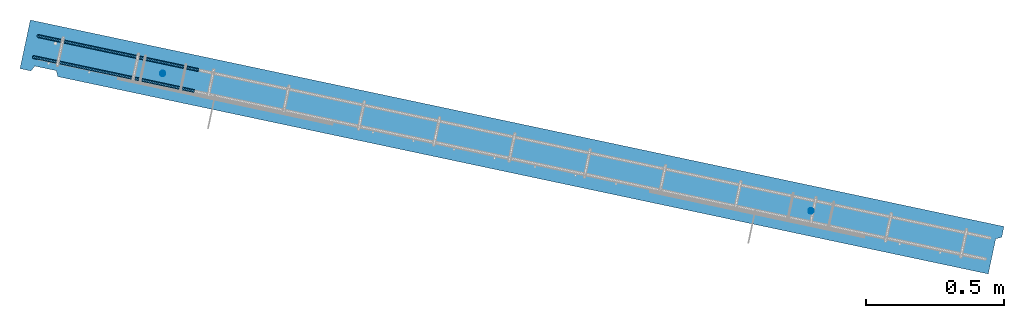
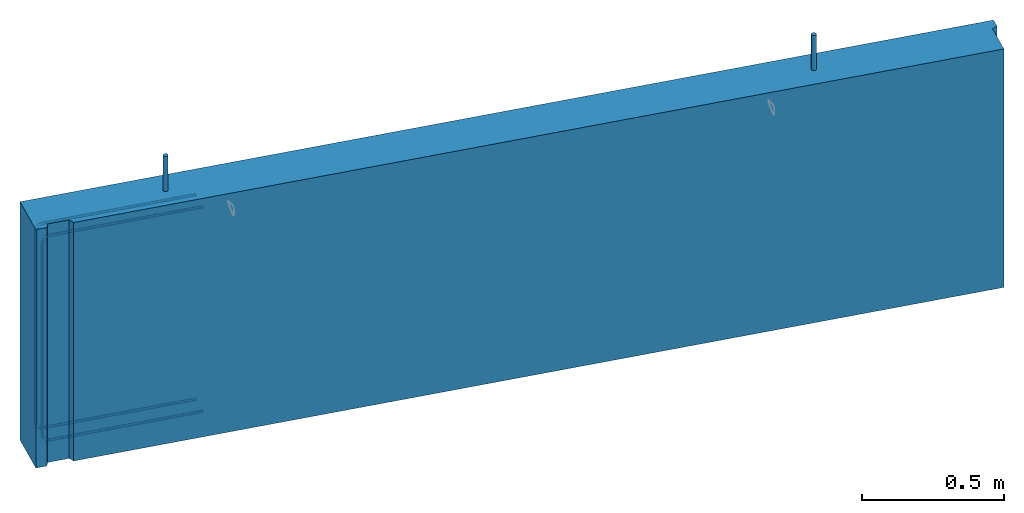
# One storey, part 1 of 5: 2 reinforcing bars, 1 wall, 1 element without a shape of its own.
"""IFC2X3 building model written with IfcOpenShell, lengths in millimetres."""

from ifc_helpers import new_model, entity, si_unit, frame, frame_2d, origin_with_axes, place, context, subcontext, project, spatial, polyline, rectangle, outline, extrude, boolean, source, transform, mapped, material, type_object, element, aggregate, save


model = new_model("IFC2X3")

# Units and contexts
model_context = context("Model", 3, precision=1e-05, world=origin_with_axes())
body_context = subcontext(model_context, "Body", "Model", "MODEL_VIEW")
ifc_project = project(units=[si_unit("LENGTHUNIT", "METRE", prefix="MILLI"), si_unit("AREAUNIT", "SQUARE_METRE"), si_unit("VOLUMEUNIT", "CUBIC_METRE"), si_unit("MASSUNIT", "GRAM", prefix="KILO"), si_unit("TIMEUNIT", "SECOND"), si_unit("PLANEANGLEUNIT", "RADIAN"), si_unit("SOLIDANGLEUNIT", "STERADIAN"), si_unit("THERMODYNAMICTEMPERATUREUNIT", "DEGREE_CELSIUS"), si_unit("LUMINOUSINTENSITYUNIT", "LUMEN")], contexts=[model_context])

# Site, building, storey
site_placement = place(None, origin_with_axes())
site = spatial("IfcSite", under=ifc_project, at=site_placement, CompositionType="ELEMENT")
building_placement = place(site_placement, origin_with_axes())
building = spatial("IfcBuilding", under=site, at=building_placement, Name="1", CompositionType="ELEMENT")
storey_placement = place(building_placement, origin_with_axes())
storey = spatial("IfcBuildingStorey", under=building, at=storey_placement, CompositionType="ELEMENT", Elevation=0.0)

# Assembly, wall, reinforcing bars
assembly_placement = place(storey_placement, origin_with_axes())
assembly = element("IfcElementAssembly", 1, at=assembly_placement, inside=storey, AssemblyPlace="NOTDEFINED", PredefinedType="REINFORCEMENT_UNIT")
ifc_material_1 = material(Name="CONCRETE/C30/37")
wall_type = type_object("IfcWallType", Name="1025X180", PredefinedType="NOTDEFINED")
wall_placement = place(assembly_placement, frame((284.52490144501, 6004.50575262965, 0.0), z_axis=(0.0, 0.0, 1.0), x_axis=(0.978240300403819, -0.207475094085641, 0.0)))
wall = element("IfcWall", 2, at=wall_placement, type_object=wall_type, material=ifc_material_1, ObjectType="1025X180", context=body_context, shape_type="CSG", body=[
    boolean("DIFFERENCE", boolean("DIFFERENCE", extrude(rectangle(XDim=3604.29647202172, YDim=180.0, at=frame_2d((0.0, 1802.14823601086), x_axis=(0.0, -1.0))), frame((0.0, 0.0, 0.0), z_axis=(0.0, 0.0, 1.0), x_axis=(0.0, -1.0, 0.0)), (0.0, 0.0, 1.0), 1025.0), extrude(outline(polyline([(0.0, 0.0), (139.999999999925, -5.13864506501704e-11), (129.999999999931, 19.9999999999877), (-9.09494701772928e-13, 19.9999999999891), (0.0, 0.0)])), frame((3604.29647202145, -89.9999999997517, -1.13686837721616e-13), z_axis=(0.0, 0.0, 1.0), x_axis=(0.0, 1.0, 0.0)), (0.0, 0.0, 1.0), 1025.0)), extrude(outline(polyline([(0.0, 0.0), (99.4114990234532, 2.09183781407773e-11), (89.4114990234559, 20.0000000000036), (10.0000000000226, 19.9999999999891), (0.0, 0.0)])), frame((40.5933694972099, -89.9999999999927, -9.09494701772928e-13), z_axis=(0.0, 0.0, 1.0), x_axis=(1.0, 0.0, 0.0)), (0.0, 0.0, 1.0), 1025.0)),
])
ifc_material_2 = material(Name="B500B")
shared_shape_1 = source(origin_with_axes(), body_context, "Body", "AdvancedSweptSolid", [
    entity("IfcSweptDiskSolid", entity("IfcTrimmedCurve", entity("IfcLine", entity("IfcCartesianPoint", [0.0, 0.0, 0.0]), entity("IfcVector", entity("IfcDirection", [0.999999999180548, -3.81768204722847e-05, -1.34697490605237e-05]), 1.0)), [entity("IfcParameterValue", 0.0)], [entity("IfcParameterValue", 799.999995410812)], True, "PARAMETER"), 9.5, None, 0.0, 799.999995410812),
])
shared_shape_2 = source(origin_with_axes(), body_context, "Body", "AdvancedSweptSolid", [
    entity("IfcSweptDiskSolid", entity("IfcTrimmedCurve", entity("IfcLine", entity("IfcCartesianPoint", [0.0, 0.0, 0.0]), entity("IfcVector", entity("IfcDirection", [0.999999999180548, -3.81768204722847e-05, -1.34697490605237e-05]), 1.0)), [entity("IfcParameterValue", 0.0)], [entity("IfcParameterValue", 799.999995410812)], True, "PARAMETER"), 9.5, None, 0.0, 799.999995410812),
])
reinforcing_bar_1_placement = place(assembly_placement, frame((1953.46447190107, 5650.29907170582, 575.000000009401), z_axis=(-0.895656494371848, 0.444746494184645, 0.0), x_axis=(0.0, 0.0, 1.0)))
reinforcing_bar_1 = element("IfcReinforcingBar", 3, at=reinforcing_bar_1_placement, material=ifc_material_2, BarRole="NOTDEFINED", CrossSectionArea=0.0, NominalDiameter=19.0, context=body_context, shape_type="MappedRepresentation", body=[
    mapped(shared_shape_1, transform((-199.999994751047, -297.985466949513, 1158.91732586056))),
    mapped(shared_shape_2, transform((-199.999994751794, 300.186784957253, -1165.34383783222))),
])
ifc_direction_1 = entity("IfcDirection", [0.0, 0.0, -1.0])
ifc_direction_2 = entity("IfcDirection", [0.0, -1.0, 0.0])
shared_shape_3 = source(origin_with_axes(), body_context, "Body", "AdvancedSweptSolid", [
    entity("IfcSweptDiskSolid", entity("IfcCompositeCurve", [entity("IfcCompositeCurveSegment", "CONTINUOUS", True, entity("IfcTrimmedCurve", entity("IfcLine", entity("IfcCartesianPoint", [0.0, 0.0, 0.0]), entity("IfcVector", ifc_direction_1, 1.0)), [entity("IfcParameterValue", 0.0)], [entity("IfcParameterValue", 564.999999999951)], True, "PARAMETER")), entity("IfcCompositeCurveSegment", "CONTINUOUS", True, entity("IfcTrimmedCurve", entity("IfcCircle", entity("IfcAxis2Placement3D", entity("IfcCartesianPoint", [29.0, -2.33576713526418e-10, -564.999999999951]), ifc_direction_2, entity("IfcDirection", [-1.0, 0.0, -6.18717668181185e-14])), 29.0), [entity("IfcParameterValue", 0.0)], [entity("IfcParameterValue", 1.5707963267949)], True, "PARAMETER")), entity("IfcCompositeCurveSegment", "CONTINUOUS", True, entity("IfcTrimmedCurve", entity("IfcLine", entity("IfcCartesianPoint", [29.0, -2.45563569478691e-10, -593.999999999951]), entity("IfcVector", entity("IfcDirection", [1.0, 0.0, 0.0]), 1.0)), [entity("IfcParameterValue", 0.0)], [entity("IfcParameterValue", 821.0)], True, "PARAMETER")), entity("IfcCompositeCurveSegment", "CONTINUOUS", True, entity("IfcTrimmedCurve", entity("IfcCircle", entity("IfcAxis2Placement3D", entity("IfcCartesianPoint", [850.0, -2.33576713526418e-10, -564.999999999951]), ifc_direction_2, ifc_direction_1), 29.0), [entity("IfcParameterValue", 0.0)], [entity("IfcParameterValue", 1.5707963267949)], True, "PARAMETER")), entity("IfcCompositeCurveSegment", "DISCONTINUOUS", True, entity("IfcTrimmedCurve", entity("IfcLine", entity("IfcCartesianPoint", [879.0, -2.33576713526418e-10, -564.999999999951]), entity("IfcVector", entity("IfcDirection", [0.0, 0.0, 1.0]), 1.0)), [entity("IfcParameterValue", 0.0)], [entity("IfcParameterValue", 564.999999999951)], True, "PARAMETER"))], False), 6.0, None, 0.0, 1954.14159265349),
])
ifc_direction_3 = entity("IfcDirection", [0.0, 0.0, -1.0])
ifc_direction_4 = entity("IfcDirection", [0.0, -1.0, 0.0])
shared_shape_4 = source(origin_with_axes(), body_context, "Body", "AdvancedSweptSolid", [
    entity("IfcSweptDiskSolid", entity("IfcCompositeCurve", [entity("IfcCompositeCurveSegment", "CONTINUOUS", True, entity("IfcTrimmedCurve", entity("IfcLine", entity("IfcCartesianPoint", [0.0, 0.0, 0.0]), entity("IfcVector", ifc_direction_3, 1.0)), [entity("IfcParameterValue", 0.0)], [entity("IfcParameterValue", 564.999999999951)], True, "PARAMETER")), entity("IfcCompositeCurveSegment", "CONTINUOUS", True, entity("IfcTrimmedCurve", entity("IfcCircle", entity("IfcAxis2Placement3D", entity("IfcCartesianPoint", [29.0, -2.33576713526418e-10, -564.999999999951]), ifc_direction_4, entity("IfcDirection", [-1.0, 0.0, -6.18717668181185e-14])), 29.0), [entity("IfcParameterValue", 0.0)], [entity("IfcParameterValue", 1.5707963267949)], True, "PARAMETER")), entity("IfcCompositeCurveSegment", "CONTINUOUS", True, entity("IfcTrimmedCurve", entity("IfcLine", entity("IfcCartesianPoint", [29.0, -2.45563569478691e-10, -593.999999999951]), entity("IfcVector", entity("IfcDirection", [1.0, 0.0, 0.0]), 1.0)), [entity("IfcParameterValue", 0.0)], [entity("IfcParameterValue", 821.0)], True, "PARAMETER")), entity("IfcCompositeCurveSegment", "CONTINUOUS", True, entity("IfcTrimmedCurve", entity("IfcCircle", entity("IfcAxis2Placement3D", entity("IfcCartesianPoint", [850.0, -2.33576713526418e-10, -564.999999999951]), ifc_direction_4, ifc_direction_3), 29.0), [entity("IfcParameterValue", 0.0)], [entity("IfcParameterValue", 1.5707963267949)], True, "PARAMETER")), entity("IfcCompositeCurveSegment", "DISCONTINUOUS", True, entity("IfcTrimmedCurve", entity("IfcLine", entity("IfcCartesianPoint", [879.0, -2.33576713526418e-10, -564.999999999951]), entity("IfcVector", entity("IfcDirection", [0.0, 0.0, 1.0]), 1.0)), [entity("IfcParameterValue", 0.0)], [entity("IfcParameterValue", 564.999999999951)], True, "PARAMETER"))], False), 6.0, None, 0.0, 1954.14159265349),
])
reinforcing_bar_2_placement = place(assembly_placement, frame((265.852100000352, 5916.46370000477, 1025.0), z_axis=(0.978240300403819, -0.207475094085641, 0.0), x_axis=(0.0, 0.0, -1.0)))
reinforcing_bar_2 = element("IfcReinforcingBar", 4, at=reinforcing_bar_2_placement, material=ifc_material_2, BarRole="NOTDEFINED", CrossSectionArea=0.0, NominalDiameter=12.0, context=body_context, shape_type="MappedRepresentation", body=[
    mapped(shared_shape_3, transform((73.0000000000002, 51.0000000002592, 634.999999999912))),
    mapped(shared_shape_4, transform((73.0000000000002, 129.000425250765, 634.999999999858))),
])
aggregate(assembly, [wall, reinforcing_bar_1, reinforcing_bar_2])

save(model, "model.ifc")
